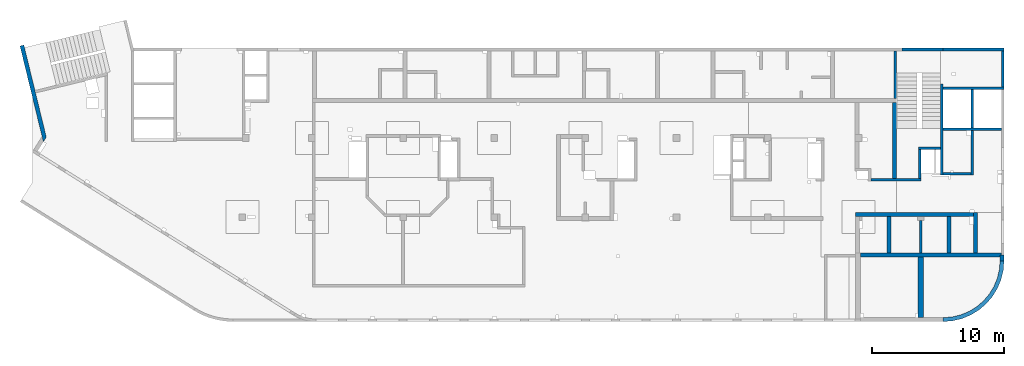
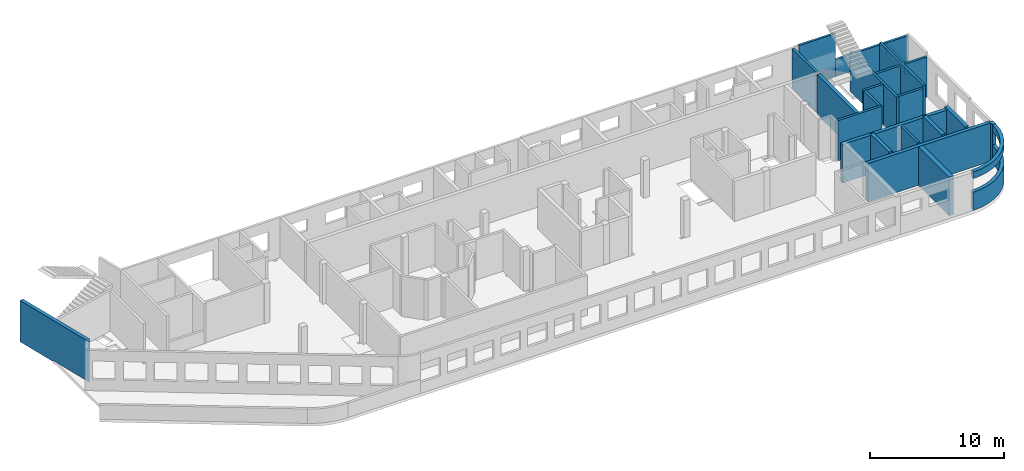
# One storey, part 5 of 10: 24 walls, 15 openings.
"""IFC4 building model written with IfcOpenShell, lengths in millimetres."""

from ifc_helpers import new_model, entity, si_unit, converted_unit, derived_unit, direction, frame, origin, place, context, subcontext, project, spatial, indexed_curve, outline, extrude, polygons, material, type_object, element, save


model = new_model("IFC4")

# Units and contexts
model_context = context("Model", 3, precision=0.01, world=origin(), true_north=direction((6.12303176911189e-17, 1.0)))
plan_context = context("Plan", 3, precision=0.01, world=origin(), true_north=direction((6.12303176911189e-17, 1.0)))
body_context = subcontext(model_context, "Body", "Model", "MODEL_VIEW")
ifc_project = project(units=[si_unit("LENGTHUNIT", "METRE", prefix="MILLI"), si_unit("AREAUNIT", "SQUARE_METRE"), si_unit("VOLUMEUNIT", "CUBIC_METRE"), converted_unit("PLANEANGLEUNIT", "DEGREE", entity("IfcRatioMeasure", 0.0174532925199433), si_unit("PLANEANGLEUNIT", "RADIAN"), dimensions=[0, 0, 0, 0, 0, 0, 0]), si_unit("MASSUNIT", "GRAM", prefix="KILO"), derived_unit("MASSDENSITYUNIT", [(si_unit("MASSUNIT", "GRAM", prefix="KILO"), 1), (si_unit("LENGTHUNIT", "METRE"), -3)]), derived_unit("MOMENTOFINERTIAUNIT", [(si_unit("LENGTHUNIT", "METRE"), 4)]), si_unit("TIMEUNIT", "SECOND"), si_unit("FREQUENCYUNIT", "HERTZ"), si_unit("THERMODYNAMICTEMPERATUREUNIT", "DEGREE_CELSIUS"), derived_unit("THERMALTRANSMITTANCEUNIT", [(si_unit("MASSUNIT", "GRAM", prefix="KILO"), 1), (si_unit("THERMODYNAMICTEMPERATUREUNIT", "KELVIN"), -1), (si_unit("TIMEUNIT", "SECOND"), -3)]), derived_unit("VOLUMETRICFLOWRATEUNIT", [(si_unit("LENGTHUNIT", "METRE"), 3), (si_unit("TIMEUNIT", "SECOND"), -1)]), derived_unit("MASSFLOWRATEUNIT", [(si_unit("MASSUNIT", "GRAM", prefix="KILO"), 1), (si_unit("TIMEUNIT", "SECOND"), -1)]), derived_unit("ROTATIONALFREQUENCYUNIT", [(si_unit("TIMEUNIT", "SECOND"), -1)]), si_unit("ELECTRICCURRENTUNIT", "AMPERE"), si_unit("ELECTRICVOLTAGEUNIT", "VOLT"), si_unit("POWERUNIT", "WATT"), si_unit("FORCEUNIT", "NEWTON", prefix="KILO"), si_unit("ILLUMINANCEUNIT", "LUX"), si_unit("LUMINOUSFLUXUNIT", "LUMEN"), si_unit("LUMINOUSINTENSITYUNIT", "CANDELA"), derived_unit("USERDEFINED", [(si_unit("MASSUNIT", "GRAM", prefix="KILO"), -1), (si_unit("LENGTHUNIT", "METRE"), -2), (si_unit("TIMEUNIT", "SECOND"), 3), (si_unit("LUMINOUSFLUXUNIT", "LUMEN"), 1)]), derived_unit("LINEARVELOCITYUNIT", [(si_unit("LENGTHUNIT", "METRE"), 1), (si_unit("TIMEUNIT", "SECOND"), -1)]), si_unit("PRESSUREUNIT", "PASCAL"), derived_unit("USERDEFINED", [(si_unit("LENGTHUNIT", "METRE"), -2), (si_unit("MASSUNIT", "GRAM", prefix="KILO"), 1), (si_unit("TIMEUNIT", "SECOND"), -2)]), derived_unit("LINEARFORCEUNIT", [(si_unit("MASSUNIT", "GRAM", prefix="KILO"), 1), (si_unit("LENGTHUNIT", "METRE"), 1), (si_unit("TIMEUNIT", "SECOND"), -2), (si_unit("LENGTHUNIT", "METRE"), -1)]), derived_unit("PLANARFORCEUNIT", [(si_unit("MASSUNIT", "GRAM", prefix="KILO"), 1), (si_unit("LENGTHUNIT", "METRE"), 1), (si_unit("TIMEUNIT", "SECOND"), -2), (si_unit("LENGTHUNIT", "METRE"), -2)])], contexts=[model_context, plan_context])

# Site, building, storey
site_placement = place(None, origin())
site = spatial("IfcSite", under=ifc_project, at=site_placement, CompositionType="ELEMENT")
building_placement = place(site_placement, origin())
building = spatial("IfcBuilding", under=site, at=building_placement, CompositionType="ELEMENT")
storey_placement = place(building_placement, frame((0.0, 0.0, 4200.0)))
storey = spatial("IfcBuildingStorey", under=building, at=storey_placement, CompositionType="ELEMENT", Elevation=4200.0)

# Walls
ifc_material = material()
wall_type_1 = type_object("IfcWallType", PredefinedType="STANDARD")
wall_1_placement = place(storey_placement, frame((65330.0002685547, 16699.999226356, -150.0), z_axis=(0.0, 0.0, 1.0), x_axis=(0.0, 1.0, 0.0)))
element("IfcWall", 1, at=wall_1_placement, inside=storey, type_object=wall_type_1, material=ifc_material, PredefinedType="NOTDEFINED", context=body_context, shape_type="SweptSolid", body=[
    extrude(outline(indexed_curve([(3600.00000000025, 100.000000000003), (-2.40637139844095e-13, 100.000000000003), (2.40637139844095e-13, -100.000000000003), (3600.00000000025, -100.000000000003), (3600.00000000025, 100.000000000003)], self_intersect=False)), origin(), (0.0, 0.0, 1.0), 3600.0),
])
wall_2_placement = place(storey_placement, frame((68870.0002685547, 17779.9992263555, -150.0), z_axis=(0.0, 0.0, 1.0), x_axis=(0.0, -1.0, 0.0)))
element("IfcWall", 2, at=wall_2_placement, inside=storey, type_object=wall_type_1, material=ifc_material, PredefinedType="NOTDEFINED", context=body_context, shape_type="SweptSolid", body=[
    extrude(outline(indexed_curve([(6894.9999999995, 100.000000000003), (0.0, 100.000000000003), (0.0, -100.000000000003), (6894.9999999995, -100.000000000003), (6894.9999999995, 100.000000000003)], self_intersect=False)), origin(), (0.0, 0.0, 1.0), 3650.0),
])
wall_3_placement = place(storey_placement, frame((68970.0002685547, 17469.9992263555, -150.0)))
element("IfcWall", 3, at=wall_3_placement, inside=storey, type_object=wall_type_1, material=ifc_material, PredefinedType="NOTDEFINED", context=body_context, shape_type="SweptSolid", body=[
    extrude(outline(indexed_curve([(4600.00000000001, 99.999999999999), (-3.30820688860804e-13, 99.9999999999989), (3.30820688860804e-13, -99.9999999999989), (4600.00000000001, -99.9999999999989), (4600.00000000001, 99.999999999999)], self_intersect=False)), origin(), (0.0, 0.0, 1.0), 3650.0),
])
wall_4_placement = place(storey_placement, frame((73370.0002685547, 14369.9992263559, -150.0), z_axis=(0.0, 0.0, 1.0), x_axis=(-1.0, 0.0, 0.0)))
element("IfcWall", 4, at=wall_4_placement, inside=storey, type_object=wall_type_1, material=ifc_material, PredefinedType="NOTDEFINED", context=body_context, shape_type="SweptSolid", body=[
    extrude(outline(indexed_curve([(4400.0, 99.9999999999989), (-3.44548632049484e-13, 99.9999999999989), (3.44548632049484e-13, -99.9999999999989), (4400.00000000001, -99.9999999999989), (4400.0, 99.9999999999989)], self_intersect=False)), origin(), (0.0, 0.0, 1.0), 3650.0),
])
wall_5_placement = place(storey_placement, frame((71170.0002685547, 17369.9992263555, -150.0), z_axis=(0.0, 0.0, 1.0), x_axis=(0.0, -1.0, 0.0)))
element("IfcWall", 5, at=wall_5_placement, inside=storey, type_object=wall_type_1, material=ifc_material, PredefinedType="NOTDEFINED", context=body_context, shape_type="Tessellation", body=[
    polygons([(6484.99999999949, -99.9999999999925, 3900.0), (0.0, -99.9999999999945, 3900.0), (0.0, -99.9999999999945, 5.41433564649196e-13), (2899.9999999995, -100.000000000003, 5.41433564649196e-13), (2899.9999999995, -100.000000000003, 3650.0), (3099.9999999995, -100.000000000003, 3650.0), (3099.9999999995, -100.000000000003, 5.41433564649196e-13), (6284.99999999949, -99.9999999999931, 5.41433564649196e-13), (6484.99999999949, -99.9999999999925, 5.41433564649196e-13), (6484.99999999949, -99.9999999999925, 3650.0), (0.0, 100.000000000003, 3900.0), (6484.99999999949, 100.000000000014, 3900.0), (6484.99999999949, 100.000000000014, 5.41433564649196e-13), (3099.9999999995, 100.000000000004, 5.41433564649196e-13), (3099.9999999995, 100.000000000004, 3650.0), (2899.9999999995, 100.000000000003, 3650.0), (2899.9999999995, 100.000000000003, 5.41433564649196e-13), (0.0, 100.000000000003, 5.41433564649196e-13), (0.0, -0.000817871099276511, 3900.0)], [[[1, 2, 3, 4, 5, 6, 7, 8, 9, 10]], [[11, 12, 13, 14, 15, 16, 17, 18]], [[3, 18, 17, 4]], [[2, 1, 12, 11, 19]], [[16, 5, 4, 17]], [[6, 15, 14, 7]], [[5, 16, 15, 6]], [[1, 10, 9, 13, 12]], [[2, 19, 11, 18, 3]], [[13, 9, 8, 7, 14]]], closed=True),
])
wall_6_placement = place(storey_placement, frame((63485.0002685547, 10525.0, -150.0)))
element("IfcWall", 6, at=wall_6_placement, inside=storey, type_object=wall_type_1, material=ifc_material, PredefinedType="NOTDEFINED", context=body_context, shape_type="SweptSolid", body=[
    extrude(outline(indexed_curve([(3795.0, 99.9999999999989), (0.0, 99.9999999999989), (0.0, -99.9999999999989), (3795.0, -99.9999999999989), (3795.0, 99.9999999999989)], self_intersect=False)), origin(), (0.0, 0.0, 1.0), 3650.0),
])
wall_7_placement = place(storey_placement, frame((71070.0002685547, 10984.999226356, -150.0), z_axis=(0.0, 0.0, 1.0), x_axis=(-1.0, 0.0, 0.0)))
element("IfcWall", 7, at=wall_7_placement, inside=storey, type_object=wall_type_1, material=ifc_material, PredefinedType="NOTDEFINED", context=body_context, shape_type="SweptSolid", body=[
    extrude(outline(indexed_curve([(2099.99999999999, 99.9999999999989), (0.0, 99.9999999999989), (0.0, -99.9999999999989), (2099.99999999999, -99.9999999999989), (2099.99999999999, 99.9999999999989)], self_intersect=False)), origin(), (0.0, 0.0, 1.0), 3650.0),
])
wall_8_placement = place(storey_placement, frame((68770.0002685547, 12929.999226356, -150.0), z_axis=(0.0, 0.0, 1.0), x_axis=(-1.0, 0.0, 0.0)))
element("IfcWall", 8, at=wall_8_placement, inside=storey, type_object=wall_type_1, material=ifc_material, PredefinedType="NOTDEFINED", context=body_context, shape_type="SweptSolid", body=[
    extrude(outline(indexed_curve([(1690.00000000001, 100.000000000003), (-3.40554850242062e-13, 100.000000000001), (3.40554850242062e-13, -100.000000000001), (1690.00000000001, -99.9999999999997), (1690.00000000001, 100.000000000003)], self_intersect=False)), origin(), (0.0, 0.0, 1.0), 3650.0),
])
wall_9_placement = place(storey_placement, frame((67180.0002685547, 12829.999226356, -150.0), z_axis=(0.0, 0.0, 1.0), x_axis=(0.0, -1.0, 0.0)))
element("IfcWall", 9, at=wall_9_placement, inside=storey, type_object=wall_type_1, material=ifc_material, PredefinedType="NOTDEFINED", context=body_context, shape_type="SweptSolid", body=[
    extrude(outline(indexed_curve([(2204.99922635597, 100.000000000003), (0.0, 100.000000000003), (0.0, -100.000000000003), (2204.99922635597, -100.000000000003), (2204.99922635597, 100.000000000003)], self_intersect=False)), origin(), (0.0, 0.0, 1.0), 3650.0),
])
wall_10_placement = place(storey_placement, frame((67270.0002685546, 4974.99922635611, -150.0), z_axis=(0.0, 0.0, 1.0), x_axis=(0.0, 1.0, 0.0)))
element("IfcWall", 10, at=wall_10_placement, inside=storey, type_object=wall_type_1, material=ifc_material, PredefinedType="NOTDEFINED", context=body_context, shape_type="SweptSolid", body=[
    extrude(outline(indexed_curve([(2475.00000000007, 100.000000000003), (0.0, 100.000000000003), (0.0, -100.000000000003), (2475.00000000007, -100.000000000003), (2475.00000000007, 100.000000000003)], self_intersect=False)), origin(), (0.0, 0.0, 1.0), 3650.0),
])

# Wall, openings
wall_11_placement = place(storey_placement, frame((65830.0002685547, 20399.9992263562, -450.0)))
wall_11 = element("IfcWall", 11, at=wall_11_placement, inside=storey, type_object=wall_type_1, material=ifc_material, PredefinedType="NOTDEFINED", context=body_context, shape_type="Tessellation", body=[
    polygons([(3139.99999999995, -99.9999999999989, 3950.0), (6.36351754440381e-12, -99.9999999999989, 3950.0), (-2.29941948998333e-12, -99.9999999999989, 300.0), (6.36351754440381e-12, -99.9999999999989, 5.41433564649196e-13), (2939.99999999996, -100.000000000003, 5.41433564649196e-13), (2939.99999999996, -100.000000000003, 30.0000000000008), (3139.99999999995, -99.9999999999989, 30.0000000000008), (3139.99999999995, -99.9999999999989, 300.000000000001), (3139.99999999995, -99.9999999999989, 1550.0), (5.82876834475029e-12, 99.9999999999989, 3950.0), (3139.99999999995, 99.9999999999989, 3950.0), (3139.99999999995, 99.9999999999989, 1550.0), (3139.99999999995, 99.9999999999989, 30.0000000000008), (2939.99999999996, 99.9999999999123, 30.0000000000008), (2939.99999999996, 99.9999999999946, 5.41433564649196e-13), (5.82876834475029e-12, 99.9999999999989, 5.41433564649196e-13), (-2.83416868963685e-12, 99.9999999999989, 299.999999999999)], [[[1, 2, 3, 4, 5, 6, 7, 8, 9]], [[10, 11, 12, 13, 14, 15, 16, 17]], [[4, 16, 15, 5]], [[2, 1, 11, 10]], [[6, 14, 13, 7]], [[14, 6, 5, 15]], [[11, 1, 9, 8, 7, 13, 12]], [[2, 10, 17, 16, 4, 3]]], closed=True),
])
opening_1_placement = place(wall_11_placement, origin())
element("IfcOpeningElement", 12, at=opening_1_placement, cuts=wall_11, PredefinedType="OPENING", context=body_context, shape_type="SweptSolid", body=[
    extrude(outline(indexed_curve([(-849.999999999993, -850.000000000002), (849.999999999994, -850.000000000002), (849.999999999994, 850.0), (-849.999999999993, 850.0), (-849.999999999993, -850.000000000002)], self_intersect=False)), frame((-46410.0, -100.0, 2150.0), z_axis=(0.0, 1.0, 0.0), x_axis=(0.0, 0.0, -1.0)), (0.0, 0.0, 1.0), 200.000000000959),
])
opening_2_placement = place(wall_11_placement, origin())
element("IfcOpeningElement", 13, at=opening_2_placement, cuts=wall_11, PredefinedType="OPENING", context=body_context, shape_type="SweptSolid", body=[
    extrude(outline(indexed_curve([(-524.999999999993, -850.000000000002), (524.999999999993, -850.000000000002), (524.999999999993, 849.999999999997), (-524.999999999993, 849.999999999997), (-524.999999999993, -850.000000000002)], self_intersect=False)), frame((-43110.0, -100.0, 2475.0), z_axis=(0.0, 1.0, 0.0), x_axis=(0.0, 0.0, -1.0)), (0.0, 0.0, 1.0), 200.000000000959),
])
opening_3_placement = place(wall_11_placement, origin())
element("IfcOpeningElement", 14, at=opening_3_placement, cuts=wall_11, PredefinedType="OPENING", context=body_context, shape_type="SweptSolid", body=[
    extrude(outline(indexed_curve([(-524.999999999993, -850.000000000002), (524.999999999993, -850.000000000002), (524.999999999993, 849.999999999997), (-524.999999999993, 849.999999999997), (-524.999999999993, -850.000000000002)], self_intersect=False)), frame((-39810.0, -100.0, 2475.0), z_axis=(0.0, 1.0, 0.0), x_axis=(0.0, 0.0, -1.0)), (0.0, 0.0, 1.0), 200.000000000959),
])
opening_4_placement = place(wall_11_placement, origin())
element("IfcOpeningElement", 15, at=opening_4_placement, cuts=wall_11, PredefinedType="OPENING", context=body_context, shape_type="SweptSolid", body=[
    extrude(outline(indexed_curve([(-524.999999999993, -849.999999999997), (524.999999999993, -849.999999999997), (524.999999999993, 850.000000000002), (-524.999999999993, 850.000000000002), (-524.999999999993, -849.999999999997)], self_intersect=False)), frame((-36510.0, -100.0, 2475.0), z_axis=(0.0, 1.0, 0.0), x_axis=(0.0, 0.0, -1.0)), (0.0, 0.0, 1.0), 200.000000000959),
])
opening_5_placement = place(wall_11_placement, origin())
element("IfcOpeningElement", 16, at=opening_5_placement, cuts=wall_11, PredefinedType="OPENING", context=body_context, shape_type="SweptSolid", body=[
    extrude(outline(indexed_curve([(-524.999999999993, -850.000000000002), (524.999999999993, -850.000000000002), (524.999999999993, 849.999999999997), (-524.999999999993, 849.999999999997), (-524.999999999993, -850.000000000002)], self_intersect=False)), frame((-33210.0, -100.0, 2475.0), z_axis=(0.0, 1.0, 0.0), x_axis=(0.0, 0.0, -1.0)), (0.0, 0.0, 1.0), 200.000000000959),
])
opening_6_placement = place(wall_11_placement, origin())
element("IfcOpeningElement", 17, at=opening_6_placement, cuts=wall_11, PredefinedType="OPENING", context=body_context, shape_type="SweptSolid", body=[
    extrude(outline(indexed_curve([(-524.999999999993, -549.999999999996), (524.999999999993, -549.999999999996), (524.999999999993, 550.000000000001), (-524.999999999993, 550.000000000001), (-524.999999999993, -549.999999999996)], self_intersect=False)), frame((-26710.0, -100.0, 2475.0), z_axis=(0.0, 1.0, 0.0), x_axis=(0.0, 0.0, -1.0)), (0.0, 0.0, 1.0), 200.000000000959),
])
opening_7_placement = place(wall_11_placement, origin())
element("IfcOpeningElement", 18, at=opening_7_placement, cuts=wall_11, PredefinedType="OPENING", context=body_context, shape_type="SweptSolid", body=[
    extrude(outline(indexed_curve([(-524.999999999993, -850.000000000006), (524.999999999993, -850.000000000006), (524.999999999993, 849.999999999997), (-524.999999999993, 849.999999999997), (-524.999999999993, -850.000000000006)], self_intersect=False)), frame((-22910.0, -100.0, 2475.0), z_axis=(0.0, 1.0, 0.0), x_axis=(0.0, 0.0, -1.0)), (0.0, 0.0, 1.0), 200.000000000959),
])
opening_8_placement = place(wall_11_placement, origin())
element("IfcOpeningElement", 19, at=opening_8_placement, cuts=wall_11, PredefinedType="OPENING", context=body_context, shape_type="SweptSolid", body=[
    extrude(outline(indexed_curve([(-524.999999999993, -850.000000000006), (524.999999999993, -850.000000000006), (524.999999999993, 849.999999999997), (-524.999999999993, 849.999999999997), (-524.999999999993, -850.000000000006)], self_intersect=False)), frame((-19610.0, -100.0, 2475.0), z_axis=(0.0, 1.0, 0.0), x_axis=(0.0, 0.0, -1.0)), (0.0, 0.0, 1.0), 200.000000000959),
])
opening_9_placement = place(wall_11_placement, origin())
element("IfcOpeningElement", 20, at=opening_9_placement, cuts=wall_11, PredefinedType="OPENING", context=body_context, shape_type="SweptSolid", body=[
    extrude(outline(indexed_curve([(-524.999999999993, -850.000000000006), (524.999999999993, -850.000000000006), (524.999999999993, 849.999999999997), (-524.999999999993, 849.999999999997), (-524.999999999993, -850.000000000006)], self_intersect=False)), frame((-16310.0, -100.0, 2475.0), z_axis=(0.0, 1.0, 0.0), x_axis=(0.0, 0.0, -1.0)), (0.0, 0.0, 1.0), 200.000000000959),
])
opening_10_placement = place(wall_11_placement, origin())
element("IfcOpeningElement", 21, at=opening_10_placement, cuts=wall_11, PredefinedType="OPENING", context=body_context, shape_type="SweptSolid", body=[
    extrude(outline(indexed_curve([(-524.999999999993, -849.999999999997), (524.999999999993, -849.999999999997), (524.999999999993, 850.000000000006), (-524.999999999993, 850.000000000006), (-524.999999999993, -849.999999999997)], self_intersect=False)), frame((-13010.0, -100.0, 2475.0), z_axis=(0.0, 1.0, 0.0), x_axis=(0.0, 0.0, -1.0)), (0.0, 0.0, 1.0), 200.000000000959),
])
opening_11_placement = place(wall_11_placement, origin())
element("IfcOpeningElement", 22, at=opening_11_placement, cuts=wall_11, PredefinedType="OPENING", context=body_context, shape_type="SweptSolid", body=[
    extrude(outline(indexed_curve([(-524.999999999993, -850.000000000006), (524.999999999993, -850.000000000006), (524.999999999993, 849.999999999997), (-524.999999999993, 849.999999999997), (-524.999999999993, -850.000000000006)], self_intersect=False)), frame((-9710.0, -100.0, 2475.0), z_axis=(0.0, 1.0, 0.0), x_axis=(0.0, 0.0, -1.0)), (0.0, 0.0, 1.0), 200.000000000959),
])
opening_12_placement = place(wall_11_placement, origin())
element("IfcOpeningElement", 23, at=opening_12_placement, cuts=wall_11, PredefinedType="OPENING", context=body_context, shape_type="SweptSolid", body=[
    extrude(outline(indexed_curve([(-524.999999999993, -850.000000000006), (524.999999999993, -850.000000000006), (524.999999999993, 849.999999999997), (-524.999999999993, 849.999999999997), (-524.999999999993, -850.000000000006)], self_intersect=False)), frame((-6410.0, -100.0, 2475.0), z_axis=(0.0, 1.0, 0.0), x_axis=(0.0, 0.0, -1.0)), (0.0, 0.0, 1.0), 200.000000000959),
])
opening_13_placement = place(wall_11_placement, origin())
element("IfcOpeningElement", 24, at=opening_13_placement, cuts=wall_11, PredefinedType="OPENING", context=body_context, shape_type="SweptSolid", body=[
    extrude(outline(indexed_curve([(-524.999999999993, -850.000000000006), (524.999999999993, -850.000000000006), (524.999999999993, 849.999999999997), (-524.999999999993, 849.999999999997), (-524.999999999993, -850.000000000006)], self_intersect=False)), frame((-3110.0, -100.0, 2475.0), z_axis=(0.0, 1.0, 0.0), x_axis=(0.0, 0.0, -1.0)), (0.0, 0.0, 1.0), 200.000000000959),
])
opening_14_placement = place(wall_11_placement, origin())
element("IfcOpeningElement", 25, at=opening_14_placement, cuts=wall_11, PredefinedType="OPENING", context=body_context, shape_type="SweptSolid", body=[
    extrude(outline(indexed_curve([(-524.999999999993, -550.000000000001), (524.999999999993, -550.000000000001), (524.999999999993, 550.000000000001), (-524.999999999993, 550.000000000001), (-524.999999999993, -550.000000000001)], self_intersect=False)), frame((-30110.0, -100.0, 2475.0), z_axis=(0.0, 1.0, 0.0), x_axis=(0.0, 0.0, -1.0)), (0.0, 0.0, 1.0), 200.000000000959),
])
opening_15_placement = place(wall_11_placement, origin())
element("IfcOpeningElement", 26, at=opening_15_placement, cuts=wall_11, PredefinedType="OPENING", context=body_context, shape_type="SweptSolid", body=[
    extrude(outline(indexed_curve([(-2100.0, -1349.99999999902), (2100.0, -1349.99999999902), (2100.0, 1349.99999999902), (-2100.0, 1349.99999999902), (-2100.0, -1349.99999999902)], self_intersect=False)), frame((-52430.0, -200.0, 1650.0), z_axis=(0.0, 1.0, 0.0), x_axis=(1.0, 0.0, 0.0)), (0.0, 0.0, 1.0), 400.000000001945),
])

# Walls
wall_12_placement = place(storey_placement, frame((68970.0002685547, 20399.999226356, -420.0)))
element("IfcWall", 27, at=wall_12_placement, inside=storey, type_object=wall_type_1, material=ifc_material, PredefinedType="NOTDEFINED", context=body_context, shape_type="SweptSolid", body=[
    extrude(outline(indexed_curve([(4600.0, 99.9999999999992), (-3.82188398575899e-13, 99.9999999999989), (3.82188398575899e-13, -99.9999999999989), (4600.0, -99.9999999999987), (4600.0, 99.9999999999992)], self_intersect=False)), origin(), (0.0, 0.0, 1.0), 1520.0),
])
wall_13_placement = place(storey_placement, frame((73470.0002685547, 17569.9992263554, -150.0), z_axis=(0.0, 0.0, 1.0), x_axis=(0.0, 1.0, 0.0)))
element("IfcWall", 28, at=wall_13_placement, inside=storey, type_object=wall_type_1, material=ifc_material, PredefinedType="NOTDEFINED", context=body_context, shape_type="SweptSolid", body=[
    extrude(outline(indexed_curve([(2730.0000000005, 100.000000000003), (0.0, 100.000000000003), (0.0, -100.000000000003), (2730.0000000005, -100.000000000003), (2730.0000000005, 100.000000000003)], self_intersect=False)), origin(), (0.0, 0.0, 1.0), 1250.0),
])
wall_type_2 = type_object("IfcWallType", PredefinedType="STANDARD")
wall_14_placement = place(storey_placement, frame((-787.544181994472, 20703.3037435836, -250.0), z_axis=(0.0, 0.0, 1.0), x_axis=(0.236826092990336, -0.971552058141473, 0.0)))
element("IfcWall", 29, at=wall_14_placement, inside=storey, type_object=wall_type_2, material=ifc_material, PredefinedType="NOTDEFINED", context=body_context, shape_type="Tessellation", body=[
    polygons([(7469.92693582263, -149.999999999999, 3750.0), (7050.74397411926, -149.999999999999, 3750.0), (7050.16407046701, -149.999999999999, 3750.0), (3540.00000000002, -149.999999999999, 3750.0), (4.33146851719357e-12, -149.999999999999, 3750.0), (4.33146851719357e-12, -149.999999999999, -5.41433564649196e-13), (3540.00000000002, -149.999999999999, -5.41433564649196e-13), (3540.00000000002, -149.999999999998, 99.9999999999995), (3940.77040872538, -149.999999999999, 99.9999999999995), (7050.74397411926, -149.999999999999, 99.9999999999995), (7469.36266127936, -149.999999999999, 99.9999999999995), (7469.36266127936, -149.999999999998, -5.41433564649196e-13), (7469.92693582263, -149.999999999999, -5.41433564649196e-13), (7469.92693582263, -149.999999999999, 99.9999999999995), (0.0, 150.000000000001, -5.41433564649196e-13), (0.0, 150.000000000001, 3250.0), (0.0, 150.000000000001, 3750.0), (200.000000000037, 150.000000000001, 3750.0), (3540.00000000001, 150.000000000001, 3750.0), (3740.0, 150.000000000001, 3750.0), (6757.3939296015, 150.000000000001, 3750.0), (7177.15679495713, 150.000000000001, 3750.0), (7177.15679495713, 150.000000000002, 99.9999999999995), (3740.00000000001, 150.000000000001, 99.9999999999995), (3540.00000000002, 150.000000000002, 99.9999999999995), (3540.00000000002, 150.000000000001, -5.41433564649196e-13), (7467.45995599307, -147.472098941924, -5.41433564649196e-13), (7467.45995599307, -147.472098941924, 99.9999999999995), (7467.17093496546, -147.754149749605, 99.9999999999995), (7467.17093496546, -147.754149749605, -5.41433564649196e-13)], [[[1, 2, 3, 4, 5, 6, 7, 8, 9, 10, 11, 12, 13, 14]], [[15, 16, 17, 18, 19, 20, 21, 22, 23, 24, 25, 26]], [[6, 15, 26, 7]], [[5, 4, 3, 2, 1, 22, 21, 20, 19, 18, 17]], [[6, 5, 17, 16, 15]], [[1, 14, 13, 27, 28, 23, 22]], [[8, 25, 24, 23, 28, 29, 11, 10, 9]], [[25, 8, 7, 26]], [[29, 28, 27, 30]], [[11, 29, 30, 12]], [[13, 12, 30, 27]]], closed=True),
])
wall_15_placement = place(storey_placement, frame((65280.0002685547, 10625.0, -150.0), z_axis=(0.0, 0.0, 1.0), x_axis=(0.0, 1.0, 0.0)))
element("IfcWall", 30, at=wall_15_placement, inside=storey, type_object=wall_type_2, material=ifc_material, PredefinedType="NOTDEFINED", context=body_context, shape_type="SweptSolid", body=[
    extrude(outline(indexed_curve([(5774.99922635596, 150.000000000001), (-2.2868418396868e-13, 150.000000000001), (2.2868418396868e-13, -150.000000000001), (5774.99922635596, -150.0), (5774.99922635596, 150.000000000001)], self_intersect=False)), origin(), (0.0, 0.0, 1.0), 3650.0),
])
wall_16_placement = place(storey_placement, frame((62720.0002685546, 4824.99922635612, -150.0)))
element("IfcWall", 31, at=wall_16_placement, inside=storey, type_object=wall_type_2, material=ifc_material, PredefinedType="NOTDEFINED", context=body_context, shape_type="SweptSolid", body=[
    extrude(outline(indexed_curve([(10550.0, -150.0), (10550.0, -6.0596314870462e-13), (10650.0, -2.8325428625114e-13), (10650.0, 150.0), (8855.0, 150.0), (8555.0, 150.0), (6830.0, 150.0), (6530.0, 150.0), (4649.99999999999, 150.0), (4449.99999999999, 150.0), (2289.99999999999, 150.0), (1989.99999999999, 150.0), (-4.84063293680244e-13, 149.999999999999), (4.84063293680246e-13, -150.0), (4350.0, -150.0), (4749.99999999999, -150.0), (10550.0, -150.0)], self_intersect=False)), origin(), (0.0, 0.0, 1.0), 3500.0),
])
wall_17_placement = place(storey_placement, frame((73420.0002685546, 4824.99922635609, -150.0), z_axis=(0.0, 0.0, 1.0), x_axis=(0.0, -1.0, 0.0)))
element("IfcWall", 32, at=wall_17_placement, inside=storey, type_object=wall_type_2, material=ifc_material, PredefinedType="NOTDEFINED", context=body_context, shape_type="Tessellation", body=[
    polygons([(0.0, -150.000000000001, 5.41433564649196e-13), (149.999999999999, -150.000000000001, 5.41433564649196e-13), (424.995930143775, -150.000000000001, 5.41433564649196e-13), (424.995930143776, -150.000000000001, 1650.0), (424.995930143776, -150.000000000001, 2900.0), (424.995930143775, -150.000000000001, 3500.0), (149.999999999999, -150.000000000001, 3500.0), (0.0, -150.000000000001, 3500.0), (424.995930143775, 150.000000000001, 5.41433564649196e-13), (0.0, 150.000000000001, 5.41433564649196e-13), (0.0, 150.000000000001, 3500.0), (424.995930143775, 150.000000000001, 3500.0), (424.995930143776, 150.000000000001, 2900.0), (424.995930143776, 150.000000000001, 1650.0), (0.0, -49.9999999999973, 5.41433564649196e-13), (0.0, -49.9999999999973, 3500.0)], [[[1, 2, 3, 4, 5, 6, 7, 8]], [[9, 10, 11, 12, 13, 14]], [[3, 2, 1, 15, 10, 9]], [[3, 9, 14, 13, 12, 6, 5, 4]], [[10, 15, 1, 8, 16, 11]], [[8, 7, 6, 12, 11, 16]]], closed=True),
])
wall_18_placement = place(storey_placement, frame((73420.0002685546, 4400.00329621238, -150.0)))
element("IfcWall", 33, at=wall_18_placement, inside=storey, type_object=wall_type_2, material=ifc_material, PredefinedType="NOTDEFINED", context=body_context, shape_type="SweptSolid", body=[
    extrude(outline(indexed_curve([(-4450.0040698544, -4600.00406985442), (-3730.40489400384, -4543.3703864854), (-3028.52463807546, -4374.86384561929), (-2361.64592337724, -4098.63363753335), (-1746.18951710861, -3721.48146670617), (-1197.30999857462, -3252.6940712798), (-728.52260314825, -2703.81455274581), (-351.370432321072, -2088.35814647718), (-75.1402242351338, -1421.47943177896), (93.3663166309807, -719.599175850587), (150.000000000001, -2.65302446678106e-11), (-150.000000000001, -2.70716782324598e-12), (-202.940185547554, -672.668836338494), (-360.457179123676, -1328.77433346646), (-618.672389577566, -1952.16099655529), (-971.227701460713, -2527.47897705804), (-1409.44203293056, -3040.56203692382), (-1922.52509279633, -3478.77636839367), (-2497.84307329908, -3831.33168027683), (-3121.22973638791, -4089.54689073073), (-3777.33523351588, -4247.06388430685), (-4450.00406985436, -4300.00406985442), (-4450.0040698544, -4600.00406985442)], self_intersect=False)), origin(), (0.0, 0.0, 1.0), 1650.0),
])
wall_19_placement = place(storey_placement, frame((73420.0002685546, 4400.00329621238, 2750.0)))
element("IfcWall", 34, at=wall_19_placement, inside=storey, type_object=wall_type_2, material=ifc_material, PredefinedType="NOTDEFINED", context=body_context, shape_type="SweptSolid", body=[
    extrude(outline(indexed_curve([(-4450.0040698544, -4600.00406985442), (-3730.40489400384, -4543.3703864854), (-3028.52463807546, -4374.86384561929), (-2361.64592337724, -4098.63363753335), (-1746.18951710861, -3721.48146670617), (-1197.30999857462, -3252.6940712798), (-728.52260314825, -2703.81455274581), (-351.370432321072, -2088.35814647718), (-75.1402242351338, -1421.47943177896), (93.3663166309807, -719.599175850587), (150.000000000001, -2.65302446678106e-11), (-150.000000000001, -2.70716782324598e-12), (-202.940185547554, -672.668836338494), (-360.457179123676, -1328.77433346646), (-618.672389577566, -1952.16099655529), (-971.227701460713, -2527.47897705804), (-1409.44203293056, -3040.56203692382), (-1922.52509279633, -3478.77636839367), (-2497.84307329908, -3831.33168027683), (-3121.22973638791, -4089.54689073073), (-3777.33523351588, -4247.06388430685), (-4450.00406985436, -4300.00406985442), (-4450.0040698544, -4600.00406985442)], self_intersect=False)), origin(), (0.0, 0.0, 1.0), 600.0),
])
wall_20_placement = place(storey_placement, frame((71425.0002685546, 4974.99922635609, -150.0), z_axis=(0.0, 0.0, 1.0), x_axis=(0.0, 1.0, 0.0)))
element("IfcWall", 35, at=wall_20_placement, inside=storey, type_object=wall_type_2, material=ifc_material, PredefinedType="NOTDEFINED", context=body_context, shape_type="SweptSolid", body=[
    extrude(outline(indexed_curve([(3074.99999999989, 150.000000000001), (0.0, 150.000000000001), (0.0, -150.000000000001), (3074.99999999989, -150.000000000001), (3074.99999999989, 150.000000000001)], self_intersect=False)), origin(), (0.0, 0.0, 1.0), 3650.0),
])
for number, where, z_axis, x_axis in (
    (36, (64860.0002685546, 4974.99922635611, -150.0), (0.0, 0.0, 1.0), (0.0, 1.0, 0.0)),
    (37, (69400.0002685546, 4974.9992263561, -150.0), (0.0, 0.0, 1.0), (0.0, 1.0, 0.0)),
):
    element("IfcWall", number, at=place(storey_placement, frame(where, z_axis=z_axis, x_axis=x_axis)), inside=storey, type_object=wall_type_2, material=ifc_material, PredefinedType="NOTDEFINED", context=body_context, shape_type="SweptSolid", body=[
        extrude(outline(indexed_curve([(2774.99999999989, 150.000000000001), (0.0, 150.000000000001), (0.0, -150.000000000001), (2774.99999999989, -150.000000000001), (2774.99999999989, 150.000000000001)], self_intersect=False)), origin(), (0.0, 0.0, 1.0), 3650.0),
    ])
wall_21_placement = place(storey_placement, frame((62320.0002685546, 7899.99922635601, -150.0)))
element("IfcWall", 38, at=wall_21_placement, inside=storey, type_object=wall_type_2, material=ifc_material, PredefinedType="NOTDEFINED", context=body_context, shape_type="SweptSolid", body=[
    extrude(outline(indexed_curve([(8955.0, 149.999999999999), (-4.3498925243293e-13, 149.999999999999), (4.3498925243293e-13, -149.999999999999), (8955.0, -149.999999999999), (8955.0, 149.999999999999)], self_intersect=False)), origin(), (0.0, 0.0, 1.0), 3500.0),
])
wall_type_3 = type_object("IfcWallType", PredefinedType="STANDARD")
wall_22_placement = place(storey_placement, frame((67270.0002685546, 99.9992263561062, -150.0), z_axis=(0.0, 0.0, 1.0), x_axis=(0.0, 1.0, 0.0)))
element("IfcWall", 39, at=wall_22_placement, inside=storey, type_object=wall_type_3, material=ifc_material, PredefinedType="NOTDEFINED", context=body_context, shape_type="Tessellation", body=[
    polygons([(1.69197988952874e-14, -199.999999999998, 5.41433564649196e-13), (4575.0, -199.999999999998, 5.41433564649196e-13), (4575.0, -199.999999999998, 3500.0), (1.52278190057586e-13, -199.999999999998, 3500.0), (4575.0, 199.999999999998, 5.41433564649196e-13), (300.000000000367, 199.999999999999, 5.41433564649196e-13), (5.41433564649196e-13, 199.999999999989, 5.41433564649196e-13), (5.41433564649196e-13, 199.999999999989, 3500.0), (300.001042198784, 199.999999999999, 3500.0), (4575.0, 199.999999999998, 3500.0)], [[[1, 2, 3, 4]], [[5, 6, 7, 8, 9, 10]], [[2, 1, 7, 6, 5]], [[2, 5, 10, 3]], [[7, 1, 4, 8]], [[4, 3, 10, 9, 8]]], closed=True),
])

save(model, "model.ifc")
